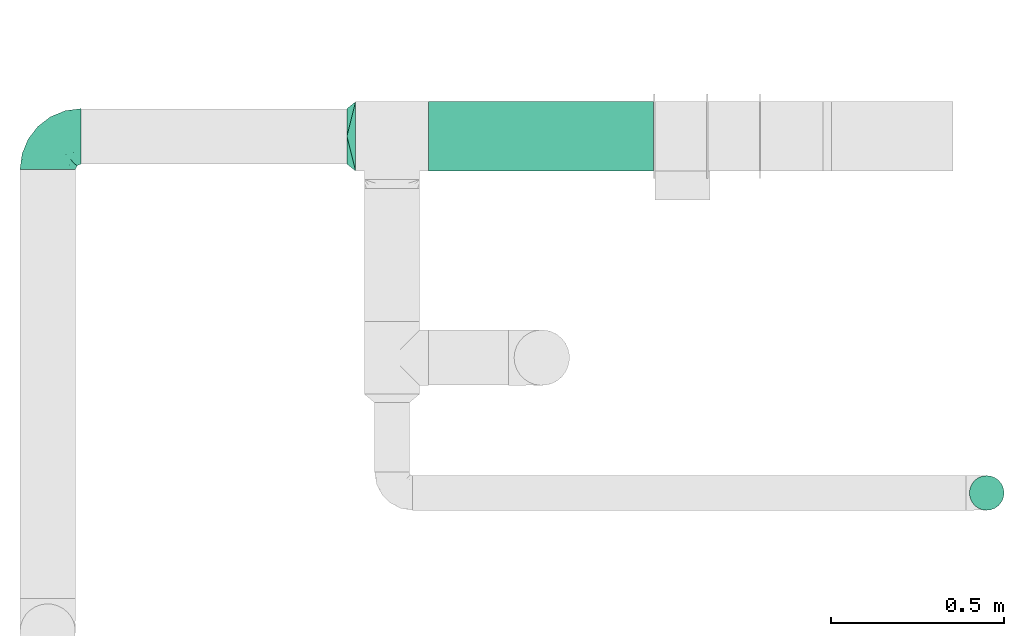
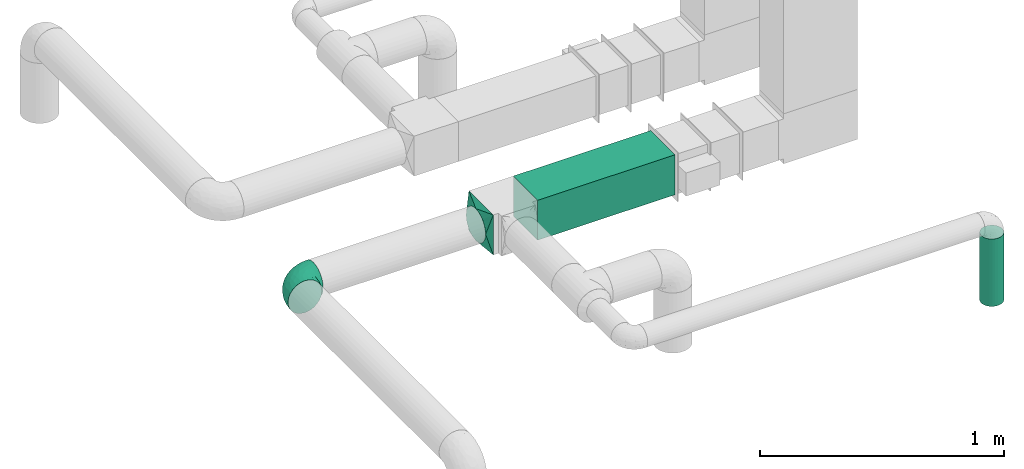
# One storey, part 5 of 12: 2 flow fittings, 2 flow segments.
"""IFC2X3 building model written with IfcOpenShell, lengths in millimetres."""

from ifc_helpers import new_model, entity, si_unit, converted_unit, derived_unit, direction, frame, frame_2d, origin, origin_2d_with_axis, place, context, subcontext, project, spatial, rectangle, circle, extrude, faceted_brep, source, transform, mapped, material, type_object, type_shapes, element, save


model = new_model("IFC2X3")

# Units and contexts
model_context = context("Model", 3, precision=0.01, world=origin(), true_north=direction((6.12303176911189e-17, 1.0)))
body_context = subcontext(model_context, "Body", "Model", "MODEL_VIEW")
ifc_project = project(units=[si_unit("LENGTHUNIT", "METRE", prefix="MILLI"), si_unit("AREAUNIT", "SQUARE_METRE"), si_unit("VOLUMEUNIT", "CUBIC_METRE"), converted_unit("PLANEANGLEUNIT", "DEGREE", entity("IfcRatioMeasure", 0.0174532925199433), si_unit("PLANEANGLEUNIT", "RADIAN"), dimensions=[0, 0, 0, 0, 0, 0, 0]), si_unit("MASSUNIT", "GRAM", prefix="KILO"), derived_unit("MASSDENSITYUNIT", [(si_unit("MASSUNIT", "GRAM", prefix="KILO"), 1), (si_unit("LENGTHUNIT", "METRE"), -3)]), si_unit("TIMEUNIT", "SECOND"), si_unit("FREQUENCYUNIT", "HERTZ"), si_unit("THERMODYNAMICTEMPERATUREUNIT", "DEGREE_CELSIUS"), derived_unit("THERMALTRANSMITTANCEUNIT", [(si_unit("MASSUNIT", "GRAM", prefix="KILO"), 1), (si_unit("THERMODYNAMICTEMPERATUREUNIT", "KELVIN"), -1), (si_unit("TIMEUNIT", "SECOND"), -3)]), derived_unit("VOLUMETRICFLOWRATEUNIT", [(si_unit("LENGTHUNIT", "METRE"), 3), (si_unit("TIMEUNIT", "SECOND"), -1)]), si_unit("ELECTRICCURRENTUNIT", "AMPERE"), si_unit("ELECTRICVOLTAGEUNIT", "VOLT"), si_unit("POWERUNIT", "WATT"), si_unit("FORCEUNIT", "NEWTON", prefix="KILO"), si_unit("ILLUMINANCEUNIT", "LUX"), si_unit("LUMINOUSFLUXUNIT", "LUMEN"), si_unit("LUMINOUSINTENSITYUNIT", "CANDELA"), derived_unit("USERDEFINED", [(si_unit("MASSUNIT", "GRAM", prefix="KILO"), -1), (si_unit("LENGTHUNIT", "METRE"), -2), (si_unit("TIMEUNIT", "SECOND"), 3), (si_unit("LUMINOUSFLUXUNIT", "LUMEN"), 1)]), derived_unit("LINEARVELOCITYUNIT", [(si_unit("LENGTHUNIT", "METRE"), 1), (si_unit("TIMEUNIT", "SECOND"), -1)]), si_unit("PRESSUREUNIT", "PASCAL"), derived_unit("USERDEFINED", [(si_unit("LENGTHUNIT", "METRE"), -2), (si_unit("MASSUNIT", "GRAM", prefix="KILO"), 1), (si_unit("TIMEUNIT", "SECOND"), -2)])], contexts=[model_context])

# Site, building, storey
site_placement = place(None, origin())
site = spatial("IfcSite", under=ifc_project, at=site_placement, CompositionType="ELEMENT")
building_placement = place(site_placement, origin())
building = spatial("IfcBuilding", under=site, at=building_placement, CompositionType="ELEMENT")
storey_placement = place(building_placement, frame((0.0, 0.0, 4000.0)))
storey = spatial("IfcBuildingStorey", under=building, at=storey_placement, Name="01 Level", CompositionType="ELEMENT", Elevation=4000.0)

# Flow segments
duct_segment_type_1 = type_object("IfcDuctSegmentType", Name="Round Duct:Air", PredefinedType="NOTDEFINED")
flow_segment_1_placement = place(storey_placement, frame((24851.8947986159, -70237.5308847274, 2603.07847999992)))
element("IfcFlowSegment", 1, at=flow_segment_1_placement, inside=storey, type_object=duct_segment_type_1, Name="Round Duct:Air", ObjectType="Round Duct:Air", context=body_context, shape_type="SweptSolid", body=[
    extrude(circle(Radius=50.0, at=origin_2d_with_axis()), frame((51.5952722359175, 51.5952722364156, 0.0), z_axis=(0.0, 0.0, 1.0), x_axis=(0.0, 1.0, 0.0)), (0.0, 0.0, 1.0), 336.921519999948),
])
duct_segment_type_2 = type_object("IfcDuctSegmentType", Name="Rectangular Duct:Air", PredefinedType="NOTDEFINED")
flow_segment_2_placement = place(storey_placement, frame((23290.9900708518, -69256.0352293172, 2900.0)))
element("IfcFlowSegment", 2, at=flow_segment_2_placement, inside=storey, type_object=duct_segment_type_2, Name="Rectangular Duct:Air", ObjectType="Rectangular Duct:Air", context=body_context, shape_type="SweptSolid", body=[
    extrude(rectangle(XDim=650.000000000004, YDim=199.999999999998, at=frame_2d((-2.1600499167107e-12, -4.33431068813661e-12), x_axis=(1.0, 0.0))), frame((325.0, 100.0, 0.0), z_axis=(0.0, 0.0, 1.0), x_axis=(-1.0, 0.0, 0.0)), (0.0, 0.0, 1.0), 200.0),
])

# Flow fittings
duct_fitting_type_1 = type_object("IfcDuctFittingType", Name="Air_Elbow short_Circ", PredefinedType="NOTDEFINED")
shared_shape_1 = source(origin(), body_context, "Body", "Brep", [
    faceted_brep([(-96.0, 40.0, -69.2820323027551), (-96.0, 20.7055236082018, -77.2740661031254), (-96.0, 0.0, -80.0), (-96.0, -20.7055236082015, -77.2740661031255), (-96.0, -40.0, -69.2820323027552), (-96.0, -56.5685424949237, -56.5685424949239), (-96.0, -69.282032302755, -40.0), (-96.0, -77.2740661031254, -20.7055236082019), (-96.0, -80.0, 0.0), (-96.0, -77.2740661031256, 20.7055236082014), (-96.0, -69.2820323027553, 40.0), (-96.0, -56.568542494924, 56.5685424949236), (-96.0, -40.0, 69.2820323027549), (-96.0, -20.705523608202, 77.2740661031254), (-96.0, 0.0, 80.0), (-96.0, 20.7055236082013, 77.2740661031256), (-96.0, 30.3527618041005, 73.2780492029404), (-96.0, 40.0, 69.2820323027553), (-96.0, 56.5685424949235, 56.5685424949241), (-96.0, 69.2820323027549, 40.0), (-96.0, 77.2740661031253, 20.7055236082021), (-96.0, 80.0, 0.0), (-96.0, 77.2740661031255, -20.7055236082016), (-96.0, 69.2820323027551, -40.0), (-96.0, 56.5685424949239, -56.5685424949238), (0.0, 96.0, -80.0), (-20.7055236082008, 96.0, -77.2740661031254), (-30.3527618041, 96.0, -73.2780492029402), (-40.0, 96.0, -69.2820323027551), (-56.5685424949229, 96.0, -56.5685424949238), (-69.2820323027542, 96.0, -40.0), (-77.2740661031245, 96.0, -20.7055236082016), (-80.0, 96.0, 0.0), (-77.2740661031244, 96.0, 20.7055236082021), (-69.2820323027539, 96.0, 40.0), (-56.5685424949226, 96.0, 56.5685424949241), (-40.0, 96.0, 69.2820323027553), (-20.7055236082004, 96.0, 77.2740661031256), (0.0, 96.0, 80.0), (20.7055236082029, 96.0, 77.2740661031254), (40.0, 96.0, 69.2820323027549), (56.5685424949249, 96.0, 56.5685424949236), (69.2820323027562, 96.0, 40.0), (77.2740661031265, 96.0, 20.7055236082014), (80.0, 96.0, 0.0), (77.2740661031264, 96.0, -20.7055236082019), (69.2820323027559, 96.0, -40.0), (56.5685424949246, 96.0, -56.5685424949239), (40.0, 96.0, -69.2820323027552), (20.7055236082025, 96.0, -77.2740661031255), (-69.6571465232348, 6.28172173912476, 79.9611058756859), (-55.1380888291464, -64.4450584799279, 39.5029426177976), (-78.4902527850466, -65.2482264041437, 44.9229732355936), (-66.7862289407348, -74.1387210661139, 22.9795507758541), (-79.9123689128389, 22.4151301859584, 77.2816866630488), (-75.1250134759213, 46.3506195730757, 68.0011973810265), (-46.2820694578435, -43.7397705581167, 60.5188244193914), (-62.9760666105318, -34.5362195419601, 70.0448030595901), (-67.1316735243184, -51.7530432423058, 58.5204707533666), (-50.4478480619551, -74.0029454268759, 0.0), (-76.2276812833835, -77.3969248578635, 0.0), (-27.189372084162, 68.980536479128, 76.8941402015288), (-6.30632028234235, 70.6421404093778, 79.9513108199466), (-47.7584488981354, -13.6212410427434, 76.3881123659885), (-29.8609237116382, -28.9682345099716, 65.8760199345924), (57.6005967886466, 33.4719572927763, 39.0176496769077), (51.7530435574228, 67.1316742002235, 58.5204705859065), (43.7397637815864, 46.2820598522933, 60.518827155348), (-74.2591571701267, -14.3645886695287, 78.2829835259588), (28.4507934888335, -28.4507934888321, 0.0), (23.3846344985257, -27.9066135199674, 24.7887114209846), (7.8513563843086, -42.4938374080907, 21.3232874317503), (-84.190871651952, 70.905997349447, 41.7100461919055), (24.7272484782103, -2.06889411058577, 53.4325037134459), (-0.0180155578363953, -25.9284255475521, 53.836744023285), (10.21505333872, -32.0754161621096, 38.020212353501), (-64.5619855594544, 27.52018553659, 77.2892967298799), (-41.7574890626937, 15.123136403511, 79.988056483004), (-24.5336756868846, -60.9669573051438, 23.5003835585885), (-29.2239240309769, -65.2117082464685, 0.0), (-8.0, -56.420471066061, 0.0), (-16.4008295437786, 51.3122057461681, 79.8609584412684), (-83.0529092063249, 83.0529092103045, 19.0855009657076), (-84.6862915010143, 84.6862915010152, 0.0), (-82.4185651555764, 62.2587017800419, 53.3339952483838), (-46.3022193149449, 75.902750025661, 67.8445262622594), (-9.5260688639158, -47.7232209131232, 35.4187162694583), (74.1387213421635, 66.7862279048973, 22.9795492840646), (14.3645870599314, 74.259154996167, 78.2829837700474), (34.536215572589, 62.976064096567, 70.0448048426748), (65.2482273833467, 78.4902510979302, 44.9229715327465), (-12.3935655196116, 25.4017250572252, 78.8652642576962), (-25.6317751341749, 1.2640655514879, 76.9124052095498), (69.8186739706361, 42.5625104806759, 16.7980672722629), (64.4450597015273, 55.1380839274934, 39.5029384026545), (60.9669574479924, 24.5336725945725, 23.5003789659965), (77.3969247188647, 76.2276802275763, 0.0), (74.002945426877, 50.4478480619565, 0.0), (-66.5995156060253, 66.5995146556305, 58.6370817132137), (-52.4774893100348, 53.0631556360015, 72.0041598972686), (-76.4857465466113, 78.9385356944492, 38.5867538667356), (-62.2587016209511, 82.4185645906685, 53.3339956492136), (28.9682276847195, 29.8609133580269, 65.8760207540895), (13.6212369177471, 47.7584433090926, 76.3881128402526), (-6.49930484510329, -53.7890406240985, 15.4645725223014), (-33.731289034344, 40.0214486160993, 79.0537019298314), (46.1336936566893, 26.2441492635858, 50.151541479116), (42.4356322774479, -10.225396744416, 0.0), (56.4204710660622, 8.0, 0.0), (50.0005984633279, 1.26038287501495, 17.5763945268078), (-45.4536887619888, -68.8356359385787, 23.6914879663761), (-33.3493864711472, -57.4572215948989, 39.1720709545353), (35.9683398342664, -11.0724559744972, 30.5391080332169), (-26.2441652621668, -46.1336984778153, 50.1515448602929), (36.6749123583047, -17.5982116941791, 14.5644188861001), (65.2117082464696, 29.2239240309784, 0.0), (49.5968730216335, 12.1440064858134, 34.8325942562253), (-47.1533280807863, 29.0746114834461, 78.9127210009486), (-0.981722938535007, 51.3162880079176, 79.4920802366619), (12.4951682569875, 20.0804783439543, 71.2292489374933), (-1.95170750213435, 1.95169859379814, 70.9272590604952), (13.0725391330592, 1.13338064801589, 63.5790506070627), (-1.93327092594732, -13.4823821925323, 63.7412032706882), (-18.9298205951927, -13.0048872663631, 70.6672094580024), (10.2253967444173, -42.4356322774466, 0.0), (-68.9805369123341, 27.1893702897943, -76.8941406355589), (-22.4151342180024, 79.9123577737124, -77.2816862456941), (-27.5201921618733, 64.5619784506715, -77.2892959136582), (-46.3506180288022, 75.1250185023919, -68.0011970559212), (-74.2591561090454, -14.364589592643, -78.2829832920378), (-42.5625109127564, -69.8186736490614, -16.7980693145318), (-66.78622820047, -74.1387209331735, -22.9795507950237), (-70.6421421271429, 6.30631801763141, -79.9513108797024), (-25.401718902627, 12.3935649209934, -78.8652635038296), (-15.1231475192353, 41.7574898106582, -79.9880566497423), (-1.2640784754681, 25.6317655571971, -76.9124065444174), (-78.9385361639639, 76.4857467527193, -38.5867530236755), (-66.5995166501766, 66.5995137008527, -58.6370816545605), (-82.4185656924104, 62.258701559575, -53.3339952529289), (60.9669567069012, 24.5336743104721, -23.5003834743896), (53.7890400497189, 6.49930371043273, -15.4645720709197), (-55.1380878256228, -64.4450583029017, -39.5029424837467), (-24.5336751436549, -60.9669572920351, -23.5003828649414), (-29.8609212227281, -28.9682353164184, -65.8760186412515), (-26.2441631797834, -46.1336980827234, -50.1515441608816), (-46.2820677406335, -43.7397707662098, -60.5188237522514), (74.1387206827049, 66.7862275406284, -22.9795512458422), (-40.0214489824224, 33.7312845774564, -79.0537024061946), (-78.4902524468744, -65.2482264004152, -44.9229731872606), (-75.902751427461, 46.3022186029078, -67.8445263463497), (-70.9059970555813, 84.1908706304995, -41.7100473389448), (-67.1316724627346, -51.7530434014037, -58.5204704180807), (-62.9760652707231, -34.536220162299, -70.044802546446), (-33.4719630839568, -57.6005950429912, -39.0176564793206), (-51.3122062597491, 16.4008248291117, -79.8609586691244), (-6.28171714934502, 69.65712797409, -79.9611061760713), (51.7530427306645, 67.1316703492073, -58.5204706539109), (-83.0529092397056, 83.0529091932979, -19.0855009185769), (68.8356349913375, 45.45368838847, -23.6914905340598), (-62.258701383479, 82.4185638376438, -53.3339962098694), (34.53621889603, 62.9760621802168, -70.0448028055675), (-1.26038544288408, -50.0005998980998, -17.5763953891677), (13.6212385978137, 47.75844096294, -76.3881120677864), (14.3645887716112, 74.2591526334116, -78.2829833202131), (65.2482261461557, 78.4902526871683, -44.9229735979605), (2.068884460932, -24.7272580800759, -53.4325021883878), (25.9284207554091, 0.0180077987247146, -53.8367428868672), (32.0754071702863, -10.2150656939878, -38.0202105656364), (47.723215348146, 9.52606271707191, -35.4187195087105), (27.9066094773716, -23.3846413342612, -24.7887058003424), (42.4938359077841, -7.8513587520169, -21.3232866357369), (28.9682309044935, 29.8609168472814, -65.8760199178674), (64.4450577206072, 55.1380878066959, -39.5029434692504), (-53.063150048133, 52.4774843719861, -72.0041634993662), (43.7397687897612, 46.2820667462245, -60.5188250739327), (-47.7584463040963, -13.6212426330217, -76.3881115880261), (57.4572201066452, 33.3493827160302, -39.1720708806551), (11.0724494499294, -35.9683446288498, -30.5391089716619), (46.1336964749623, 26.2441642243134, -50.1515465265606), (17.5982028158329, -36.6749194460897, -14.5644209948051), (-12.1440097531109, -49.5968729214507, -34.8325978072281), (-29.0746218055845, 47.1533256390974, -78.912719851915), (-51.3162911259858, 0.981717610547608, -79.4920798409907), (-20.0804667507281, -12.4951842966219, -71.2292388196267), (-1.95170139871169, 1.95169735730944, -70.9272563527003), (-1.13337124471279, -13.072540998247, -63.5790448193562), (13.4823844636247, 1.93327501577089, -63.7412039856557), (13.0048800657406, 18.9298191902065, -70.6672121474654)], [[[0, 1, 2, 3, 4, 5, 6, 7, 8, 9, 10, 11, 12, 13, 14, 15, 16, 17, 18, 19, 20, 21, 22, 23, 24]], [[25, 26, 27, 28, 29, 30, 31, 32, 33, 34, 35, 36, 37, 38, 39, 40, 41, 42, 43, 44, 45, 46, 47, 48, 49]], [[15, 14, 50]], [[51, 52, 53]], [[54, 55, 17]], [[56, 57, 58]], [[59, 53, 60]], [[37, 61, 62]], [[63, 57, 64]], [[65, 66, 67]], [[52, 11, 10]], [[58, 57, 12]], [[68, 14, 13]], [[69, 70, 71]], [[72, 20, 19]], [[57, 63, 68]], [[73, 74, 75]], [[76, 50, 77]], [[13, 12, 57]], [[17, 55, 18]], [[17, 16, 15, 54]], [[78, 79, 80]], [[81, 62, 61]], [[21, 82, 83]], [[57, 56, 64]], [[21, 20, 82]], [[84, 72, 19]], [[12, 11, 58]], [[19, 18, 84]], [[36, 85, 61]], [[75, 74, 86]], [[53, 9, 60]], [[53, 10, 9]], [[42, 87, 43]], [[66, 41, 40]], [[88, 89, 39]], [[42, 41, 90]], [[40, 39, 89]], [[91, 77, 92]], [[87, 42, 90]], [[93, 94, 95]], [[89, 66, 40]], [[87, 96, 43]], [[36, 35, 85]], [[93, 97, 87]], [[85, 98, 99]], [[33, 100, 34]], [[82, 100, 33]], [[100, 98, 101]], [[102, 89, 103]], [[83, 82, 32]], [[78, 80, 104]], [[36, 61, 37]], [[61, 85, 99]], [[105, 77, 91]], [[102, 106, 67]], [[35, 34, 101]], [[37, 62, 38]], [[107, 108, 109]], [[110, 51, 53]], [[88, 39, 38]], [[78, 110, 79]], [[59, 79, 110]], [[51, 110, 111]], [[75, 70, 112]], [[111, 86, 113]], [[107, 114, 69]], [[106, 102, 73]], [[115, 93, 95]], [[62, 88, 38]], [[115, 95, 108]], [[116, 95, 65]], [[95, 116, 109]], [[68, 50, 14]], [[76, 77, 117]], [[76, 117, 99]], [[84, 55, 98]], [[101, 85, 35]], [[98, 55, 99]], [[81, 61, 105]], [[62, 118, 88]], [[67, 66, 89]], [[90, 66, 94]], [[52, 58, 11]], [[58, 51, 111]], [[50, 63, 77]], [[92, 77, 63]], [[119, 91, 120]], [[81, 118, 62]], [[120, 121, 119]], [[73, 112, 116]], [[120, 122, 121]], [[123, 122, 120]], [[74, 64, 113]], [[92, 123, 120]], [[74, 113, 86]], [[73, 121, 122]], [[76, 99, 55]], [[61, 99, 105]], [[9, 8, 60]], [[96, 87, 97]], [[96, 44, 43]], [[89, 88, 103]], [[57, 68, 13]], [[50, 68, 63]], [[100, 101, 34]], [[85, 101, 98]], [[55, 84, 18]], [[72, 98, 100]], [[105, 91, 81]], [[118, 91, 103]], [[91, 118, 81]], [[88, 118, 103]], [[98, 72, 84]], [[72, 100, 82]], [[82, 20, 72]], [[32, 82, 33]], [[53, 52, 10]], [[58, 52, 51]], [[66, 90, 41]], [[87, 90, 94]], [[76, 55, 54]], [[15, 50, 54]], [[50, 76, 54]], [[110, 53, 59]], [[111, 110, 78]], [[78, 104, 86]], [[111, 113, 56]], [[78, 86, 111]], [[86, 71, 75]], [[70, 75, 71]], [[73, 75, 112]], [[104, 124, 71]], [[95, 109, 108]], [[70, 114, 112]], [[94, 65, 95]], [[114, 109, 112]], [[69, 114, 70]], [[109, 114, 107]], [[73, 116, 106]], [[112, 109, 116]], [[66, 65, 94]], [[106, 116, 65]], [[97, 93, 115]], [[86, 104, 71]], [[124, 104, 80]], [[124, 69, 71]], [[94, 93, 87]], [[102, 67, 89]], [[65, 67, 106]], [[111, 56, 58]], [[64, 56, 113]], [[77, 105, 117]], [[99, 117, 105]], [[123, 63, 64]], [[91, 92, 120]], [[63, 123, 92]], [[122, 64, 74]], [[64, 122, 123]], [[73, 122, 74]], [[73, 102, 121]], [[119, 121, 102]], [[102, 103, 119]], [[91, 119, 103]], [[0, 125, 1]], [[126, 127, 128]], [[3, 2, 129]], [[130, 59, 131]], [[1, 132, 2]], [[133, 134, 135]], [[136, 137, 138]], [[139, 108, 140]], [[23, 138, 24]], [[130, 141, 142]], [[23, 22, 136]], [[143, 144, 145]], [[146, 46, 45]], [[147, 134, 133]], [[131, 6, 148]], [[0, 24, 149]], [[131, 60, 7]], [[150, 31, 30]], [[151, 4, 152]], [[153, 151, 145]], [[5, 4, 151]], [[4, 3, 152]], [[154, 132, 125]], [[5, 148, 6]], [[26, 25, 155]], [[3, 129, 152]], [[6, 131, 7]], [[48, 47, 156]], [[21, 83, 157]], [[139, 158, 115]], [[32, 31, 157]], [[157, 136, 22]], [[30, 159, 150]], [[49, 48, 160]], [[124, 80, 161]], [[29, 159, 30]], [[28, 27, 26, 126]], [[149, 125, 0]], [[127, 155, 134]], [[160, 162, 163]], [[164, 47, 46]], [[29, 28, 128]], [[165, 166, 167]], [[49, 163, 25]], [[168, 167, 166]], [[1, 125, 132]], [[139, 115, 108]], [[69, 169, 170]], [[162, 160, 171]], [[156, 160, 48]], [[172, 164, 146]], [[149, 137, 173]], [[146, 96, 97]], [[160, 174, 171]], [[143, 152, 175]], [[156, 174, 160]], [[125, 149, 173]], [[126, 128, 28]], [[97, 115, 158]], [[157, 22, 21]], [[158, 172, 146]], [[146, 45, 96]], [[172, 158, 176]], [[167, 169, 177]], [[176, 168, 178]], [[124, 179, 69]], [[144, 143, 165]], [[79, 130, 142]], [[45, 44, 96]], [[79, 142, 80]], [[180, 142, 153]], [[142, 180, 161]], [[163, 155, 25]], [[181, 134, 147]], [[127, 181, 173]], [[159, 128, 137]], [[138, 149, 24]], [[137, 128, 173]], [[154, 125, 147]], [[132, 182, 129]], [[145, 151, 152]], [[148, 151, 141]], [[164, 156, 47]], [[156, 172, 176]], [[155, 162, 134]], [[135, 134, 162]], [[183, 133, 184]], [[154, 182, 132]], [[184, 185, 183]], [[165, 177, 180]], [[184, 186, 185]], [[187, 186, 184]], [[166, 171, 178]], [[135, 187, 184]], [[166, 178, 168]], [[165, 185, 186]], [[127, 173, 128]], [[125, 173, 147]], [[60, 131, 59]], [[60, 8, 7]], [[132, 129, 2]], [[152, 129, 175]], [[160, 163, 49]], [[155, 163, 162]], [[136, 138, 23]], [[149, 138, 137]], [[128, 159, 29]], [[150, 137, 136]], [[147, 133, 154]], [[182, 133, 175]], [[133, 182, 154]], [[129, 182, 175]], [[137, 150, 159]], [[150, 136, 157]], [[32, 157, 83]], [[157, 31, 150]], [[146, 164, 46]], [[156, 164, 172]], [[151, 148, 5]], [[131, 148, 141]], [[127, 126, 155]], [[26, 155, 126]], [[158, 146, 97]], [[176, 158, 139]], [[139, 140, 168]], [[176, 178, 174]], [[139, 168, 176]], [[168, 170, 167]], [[169, 167, 170]], [[165, 167, 177]], [[140, 107, 170]], [[142, 161, 80]], [[169, 179, 177]], [[141, 153, 142]], [[179, 161, 177]], [[69, 179, 169]], [[161, 179, 124]], [[165, 180, 144]], [[177, 161, 180]], [[151, 153, 141]], [[144, 180, 153]], [[59, 130, 79]], [[168, 140, 170]], [[107, 140, 108]], [[107, 69, 170]], [[141, 130, 131]], [[143, 145, 152]], [[153, 145, 144]], [[176, 174, 156]], [[171, 174, 178]], [[173, 181, 147]], [[127, 134, 181]], [[187, 162, 171]], [[133, 135, 184]], [[162, 187, 135]], [[186, 171, 166]], [[171, 186, 187]], [[165, 186, 166]], [[165, 143, 185]], [[183, 185, 143]], [[143, 175, 183]], [[133, 183, 175]]]),
])
type_shapes(duct_fitting_type_1, [shared_shape_1])
flow_fitting_1_placement = place(storey_placement, frame((22191.748982204, -69156.0352293172, 3000.0), z_axis=(0.0, 0.0, 1.0), x_axis=(-1.0, 0.0, 0.0)))
element("IfcFlowFitting", 3, at=flow_fitting_1_placement, inside=storey, type_object=duct_fitting_type_1, Name="elbow_short_001:Air_Elbow short_Circ", ObjectType="elbow_short_001:Air_Elbow short_Circ", context=body_context, shape_type="MappedRepresentation", body=[
    mapped(shared_shape_1, transform((0.0, 0.0, 0.0), scale=1.0)),
])
ifc_material = material(Name="Material_Duct")
duct_fitting_type_2 = type_object("IfcDuctFittingType", Name="Air_Multi shape transition_Circ", PredefinedType="NOTDEFINED", material=ifc_material)
shared_shape_2 = source(origin(), body_context, "Body", "Brep", [
    faceted_brep([(25.0, -30.614674589207, -73.9103626009021), (25.0, -22.8665162204521, -75.4515671248636), (25.0, -15.1183578516973, -76.9927716488251), (25.0, -11.3387683887729, -77.7445787366186), (25.0, -7.55917892584856, -78.4963858244121), (25.0, 0.0, -80.0), (25.0, 7.55917891579331, -78.4963858264122), (25.0, 15.1183578315867, -76.9927716528254), (25.0, 18.9924370209918, -76.2221693898445), (25.0, 22.8665162103969, -75.4515671268637), (25.0, 30.6146745892071, -73.9103626009021), (25.0, 37.1031415656363, -69.5749075744073), (25.0, 43.5916085420654, -65.2394525479125), (25.0, 50.0800755184946, -60.9039975214177), (25.0, 56.5685424949238, -56.5685424949229), (25.0, 60.9039975214186, -50.0800755184938), (25.0, 65.2394525479134, -43.5916085420646), (25.0, 69.5749075744082, -37.1031415656355), (25.0, 73.910362600903, -30.6146745892063), (25.0, 75.4515671248645, -22.8665162204514), (25.0, 76.992771648826, -15.1183578516966), (25.0, 77.7445787366195, -11.3387683887722), (25.0, 78.496385824413, -7.55917892584782), (25.0, 80.0, 0.0), (25.0, 78.4963858264131, 7.55917891579322), (25.0, 76.9927716528263, 15.1183578315867), (25.0, 76.2221693898455, 18.9924370209917), (25.0, 75.4515671268647, 22.8665162103968), (25.0, 73.910362600903, 30.614674589207), (25.0, 69.5749075744082, 37.1031415656362), (25.0, 65.2394525479135, 43.5916085420653), (25.0, 60.9039975214187, 50.0800755184945), (25.0, 56.5685424949239, 56.5685424949237), (25.0, 50.0800755184948, 60.9039975214185), (25.0, 43.5916085420656, 65.2394525479133), (25.0, 37.1031415656365, 69.5749075744081), (25.0, 30.6146745892073, 73.9103626009029), (25.0, 22.8665162204525, 75.4515671248644), (25.0, 15.1183578516976, 76.992771648826), (25.0, 11.3387683887732, 77.7445787366195), (25.0, 7.55917892584888, 78.496385824413), (25.0, 0.0, 80.0), (25.0, -7.55917891579326, 78.4963858264132), (25.0, -15.1183578315867, 76.9927716528263), (25.0, -18.9924370209918, 76.2221693898455), (25.0, -22.8665162103969, 75.4515671268647), (25.0, -30.6146745892071, 73.910362600903), (25.0, -37.1031415656362, 69.5749075744082), (25.0, -43.5916085420654, 65.2394525479134), (25.0, -50.0800755184946, 60.9039975214187), (25.0, -56.5685424949237, 56.5685424949239), (25.0, -60.9039975214185, 50.0800755184947), (25.0, -65.2394525479133, 43.5916085420656), (25.0, -69.5749075744081, 37.1031415656364), (25.0, -73.9103626009029, 30.6146745892072), (25.0, -75.4515671248645, 22.8665162204524), (25.0, -76.992771648826, 15.1183578516975), (25.0, -77.7445787366195, 11.3387683887731), (25.0, -78.496385824413, 7.55917892584876), (25.0, -80.0, 0.0), (25.0, -78.4963858264131, -7.55917891579276), (25.0, -76.9927716528262, -15.1183578315862), (25.0, -76.2221693898453, -18.9924370209913), (25.0, -75.4515671268645, -22.8665162103963), (25.0, -73.9103626009028, -30.6146745892065), (25.0, -69.574907574408, -37.1031415656356), (25.0, -65.2394525479132, -43.5916085420648), (25.0, -60.9039975214184, -50.0800755184939), (25.0, -56.5685424949236, -56.5685424949231), (25.0, -50.0800755184945, -60.9039975214178), (25.0, -43.5916085420653, -65.2394525479126), (25.0, -37.1031415656362, -69.5749075744073), (0.0, -100.0, 100.0), (0.0, 100.0, 100.0), (0.0, 100.0, -100.0), (0.0, -100.0, -100.0), (6.50713916945186, -73.9714433221932, 94.7942886644397), (9.76070875417778, -60.9571649832894, 92.1914329966587), (22.0035695847259, -11.9857216610963, 82.3971443322195), (19.0071391694519, -23.9714433221927, 84.7942886644389), (16.0107087541778, -35.9571649832891, 87.1914329966584), (13.0142783389037, -47.9428866443855, 89.5885773288778), (12.5000000004112, -79.9443399349057, 76.5204921859004), (9.76070845754317, -92.191433233966, 60.9571661698283), (13.0142779433909, -89.5885776452877, 47.9428882264372), (16.0107084575432, -87.1914332339658, 35.9571661698279), (19.0071389716954, -84.7942888226439, 23.9714441132186), (20.5053542287716, -83.5957166169829, 17.978583084914), (22.0035694858477, -82.3971444113219, 11.9857220566093), (3.25356948584772, -97.3971444113226, 86.9857220566105), (6.50713897169545, -94.7942888226443, 73.9714441132194), (3.25356958472593, -86.9857216610971, 97.3971443322206), (3.25356958472592, -97.39714433222, -86.9857216610962), (6.50713916945185, -94.7942886644392, -73.9714433221924), (9.76070875417777, -92.1914329966583, -60.9571649832887), (13.0142783389037, -89.5885773288775, -47.9428866443849), (16.0107087541778, -87.1914329966581, -35.9571649832885), (19.0071391694518, -84.7942886644387, -23.9714433221921), (22.0035695847259, -82.3971443322194, -11.9857216610957), (12.5000000004112, -76.5204921859, -79.9443399349049), (9.76070845754315, -60.9571661698279, -92.1914332339651), (13.0142779433909, -47.9428882264369, -89.5885776452868), (16.0107084575432, -35.9571661698276, -87.1914332339649), (19.0071389716954, -23.9714441132183, -84.794288822643), (20.5053542287716, -17.9785830849137, -83.595716616982), (22.0035694858477, -11.9857220566091, -82.397144411321), (3.25356948584772, -86.9857220566099, -97.3971444113217), (6.50713897169543, -73.9714441132189, -94.7942888226434), (3.25356958472593, 86.9857216610957, -97.3971443322191), (6.50713916945185, 73.9714433221921, -94.7942886644383), (9.76070875417778, 60.9571649832884, -92.1914329966574), (13.0142783389037, 47.9428866443848, -89.5885773288765), (16.0107087541778, 35.9571649832886, -87.1914329966572), (19.0071391694519, 23.9714433221924, -84.7942886644378), (22.0035695847259, 11.9857216610961, -82.3971443322185), (12.5000000004112, 79.944339934905, -76.5204921858991), (9.76070845754316, 92.1914332339651, -60.957166169827), (13.0142779433909, 89.588577645287, -47.942888226436), (16.0107084575432, 87.1914332339653, -35.9571661698268), (19.0071389716954, 84.7942888226435, -23.9714441132175), (20.5053542287716, 83.5957166169826, -17.9785830849129), (22.0035694858477, 82.3971444113217, -11.9857220566083), (3.25356948584772, 97.3971444113213, -86.985722056609), (6.50713897169544, 94.7942888226432, -73.971444113218), (3.25356958472593, 97.3971443322187, 86.9857216610977), (6.50713916945185, 94.7942886644381, 73.9714433221937), (9.76070875417778, 92.1914329966574, 60.9571649832898), (13.0142783389037, 89.5885773288767, 47.9428866443859), (16.0107087541778, 87.1914329966576, 35.9571649832893), (19.0071391694519, 84.7942886644384, 23.9714433221928), (22.0035695847259, 82.3971443322192, 11.9857216610963), (12.5000000004112, 76.5204921858994, 79.9443399349061), (9.76070845754316, 60.957166169827, 92.1914332339665), (13.0142779433909, 47.9428882264362, 89.5885776452881), (16.0107084575432, 35.9571661698272, 87.191433233966), (19.0071389716954, 23.9714441132182, 84.794288822644), (20.5053542287716, 17.9785830849137, 83.595716616983), (22.0035694858477, 11.9857220566092, 82.397144411322), (3.25356948584772, 86.9857220566086, 97.3971444113232), (6.50713897169544, 73.9714441132178, 94.7942888226448)], [[[0, 1, 2, 3, 4, 5, 6, 7, 8, 9, 10, 11, 12, 13, 14, 15, 16, 17, 18, 19, 20, 21, 22, 23, 24, 25, 26, 27, 28, 29, 30, 31, 32, 33, 34, 35, 36, 37, 38, 39, 40, 41, 42, 43, 44, 45, 46, 47, 48, 49, 50, 51, 52, 53, 54, 55, 56, 57, 58, 59, 60, 61, 62, 63, 64, 65, 66, 67, 68, 69, 70, 71]], [[72, 73, 74, 75]], [[76, 48, 77]], [[48, 47, 46, 77]], [[78, 79, 80, 81, 77, 46, 45, 44, 43, 42, 41]], [[49, 82, 50]], [[56, 55, 54, 83, 84, 85, 86, 87, 88, 59, 58, 57]], [[82, 72, 89]], [[82, 51, 50]], [[83, 52, 90]], [[91, 72, 82]], [[54, 53, 52, 83]], [[90, 52, 51]], [[51, 82, 89]], [[90, 51, 89]], [[76, 49, 48]], [[49, 76, 91]], [[82, 49, 91]], [[88, 87, 86, 85, 84, 83, 90, 89, 72, 75, 92, 93, 94, 95, 96, 97, 98, 59]], [[93, 66, 94]], [[66, 65, 64, 94]], [[98, 97, 96, 95, 94, 64, 63, 62, 61, 60, 59]], [[67, 99, 68]], [[2, 1, 0, 100, 101, 102, 103, 104, 105, 5, 4, 3]], [[99, 75, 106]], [[99, 69, 68]], [[100, 70, 107]], [[92, 75, 99]], [[0, 71, 70, 100]], [[107, 70, 69]], [[69, 99, 106]], [[107, 69, 106]], [[93, 67, 66]], [[67, 93, 92]], [[99, 67, 92]], [[105, 104, 103, 102, 101, 100, 107, 106, 75, 74, 108, 109, 110, 111, 112, 113, 114, 5]], [[109, 12, 110]], [[12, 11, 10, 110]], [[114, 113, 112, 111, 110, 10, 9, 8, 7, 6, 5]], [[13, 115, 14]], [[20, 19, 18, 116, 117, 118, 119, 120, 121, 23, 22, 21]], [[115, 74, 122]], [[115, 15, 14]], [[116, 16, 123]], [[108, 74, 115]], [[18, 17, 16, 116]], [[123, 16, 15]], [[15, 115, 122]], [[123, 15, 122]], [[109, 13, 12]], [[13, 109, 108]], [[115, 13, 108]], [[74, 73, 124, 125, 126, 127, 128, 129, 130, 23, 121, 120, 119, 118, 117, 116, 123, 122]], [[125, 30, 126]], [[30, 29, 28, 126]], [[130, 129, 128, 127, 126, 28, 27, 26, 25, 24, 23]], [[31, 131, 32]], [[38, 37, 36, 132, 133, 134, 135, 136, 137, 41, 40, 39]], [[131, 73, 138]], [[131, 33, 32]], [[132, 34, 139]], [[124, 73, 131]], [[36, 35, 34, 132]], [[139, 34, 33]], [[33, 131, 138]], [[139, 33, 138]], [[125, 31, 30]], [[31, 125, 124]], [[131, 31, 124]], [[73, 72, 91, 76, 77, 81, 80, 79, 78, 41, 137, 136, 135, 134, 133, 132, 139, 138]]]),
])
type_shapes(duct_fitting_type_2, [shared_shape_2])
flow_fitting_2_placement = place(storey_placement, frame((23080.9900708518, -69156.0352293172, 3000.0), z_axis=(0.0, 0.0, 1.0), x_axis=(-1.0, 0.0, 0.0)))
element("IfcFlowFitting", 4, at=flow_fitting_2_placement, inside=storey, type_object=duct_fitting_type_2, material=ifc_material, Name="multi_shape_trans_001:Air_Multi shape transition_Circ", ObjectType="multi_shape_trans_001:Air_Multi shape transition_Circ", context=body_context, shape_type="MappedRepresentation", body=[
    mapped(shared_shape_2, transform((0.0, 0.0, 0.0), scale=1.0)),
])

save(model, "model.ifc")
